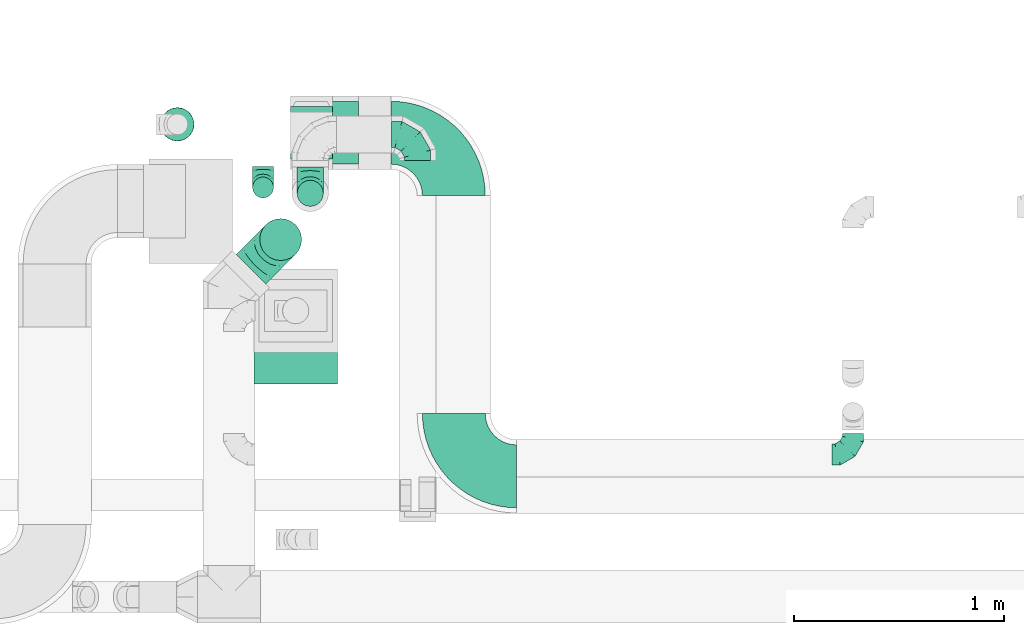
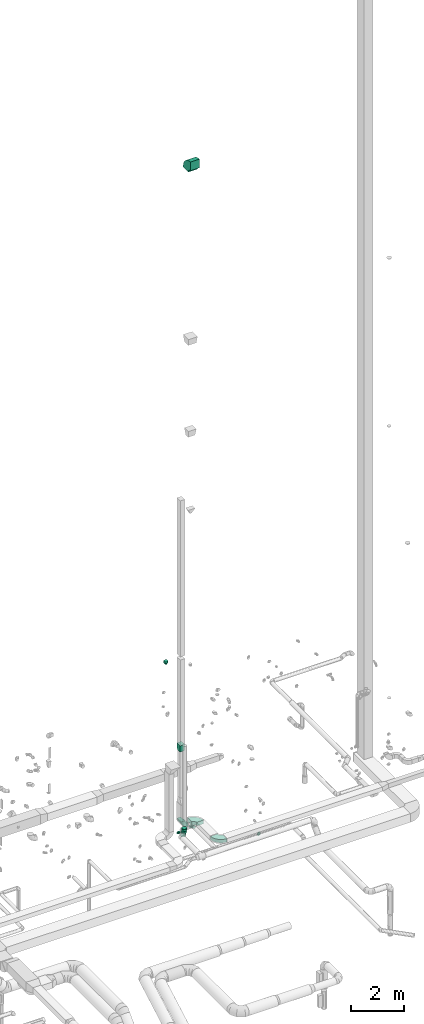
# One storey, part 66 of 97: 11 flow fittings, 1 flow segment.
"""IFC2X3 building model written with IfcOpenShell, lengths in millimetres."""

from ifc_helpers import new_model, entity, si_unit, converted_unit, derived_unit, direction, frame, frame_2d, origin, origin_2d_with_axis, place, context, subcontext, project, spatial, polyline, circle_curve, parameter, trimmed, segment, composite_curve, circle, outline, extrude, faceted_brep, source, transform, mapped, material, type_object, type_shapes, element, save


model = new_model("IFC2X3")

# Units and contexts
model_context = context("Model", 3, precision=0.01, world=origin(), true_north=direction((6.12303176911189e-17, 1.0)))
body_context = subcontext(model_context, "Body", "Model", "MODEL_VIEW")
ifc_project = project(units=[si_unit("LENGTHUNIT", "METRE", prefix="MILLI"), si_unit("AREAUNIT", "SQUARE_METRE"), si_unit("VOLUMEUNIT", "CUBIC_METRE"), converted_unit("PLANEANGLEUNIT", "DEGREE", entity("IfcRatioMeasure", 0.0174532925199433), si_unit("PLANEANGLEUNIT", "RADIAN"), dimensions=[0, 0, 0, 0, 0, 0, 0]), si_unit("MASSUNIT", "GRAM", prefix="KILO"), derived_unit("MASSDENSITYUNIT", [(si_unit("MASSUNIT", "GRAM", prefix="KILO"), 1), (si_unit("LENGTHUNIT", "METRE"), -3)]), derived_unit("MOMENTOFINERTIAUNIT", [(si_unit("LENGTHUNIT", "METRE"), 4)]), si_unit("TIMEUNIT", "SECOND"), si_unit("FREQUENCYUNIT", "HERTZ"), si_unit("THERMODYNAMICTEMPERATUREUNIT", "DEGREE_CELSIUS"), derived_unit("THERMALTRANSMITTANCEUNIT", [(si_unit("MASSUNIT", "GRAM", prefix="KILO"), 1), (si_unit("THERMODYNAMICTEMPERATUREUNIT", "KELVIN"), -1), (si_unit("TIMEUNIT", "SECOND"), -3)]), derived_unit("VOLUMETRICFLOWRATEUNIT", [(si_unit("LENGTHUNIT", "METRE"), 3), (si_unit("TIMEUNIT", "SECOND"), -1)]), derived_unit("MASSFLOWRATEUNIT", [(si_unit("MASSUNIT", "GRAM", prefix="KILO"), 1), (si_unit("TIMEUNIT", "SECOND"), -1)]), derived_unit("ROTATIONALFREQUENCYUNIT", [(si_unit("TIMEUNIT", "SECOND"), -1)]), si_unit("ELECTRICCURRENTUNIT", "AMPERE"), si_unit("ELECTRICVOLTAGEUNIT", "VOLT"), si_unit("POWERUNIT", "WATT"), si_unit("FORCEUNIT", "NEWTON", prefix="KILO"), si_unit("ILLUMINANCEUNIT", "LUX"), si_unit("LUMINOUSFLUXUNIT", "LUMEN"), si_unit("LUMINOUSINTENSITYUNIT", "CANDELA"), derived_unit("USERDEFINED", [(si_unit("MASSUNIT", "GRAM", prefix="KILO"), -1), (si_unit("LENGTHUNIT", "METRE"), -2), (si_unit("TIMEUNIT", "SECOND"), 3), (si_unit("LUMINOUSFLUXUNIT", "LUMEN"), 1)]), derived_unit("LINEARVELOCITYUNIT", [(si_unit("LENGTHUNIT", "METRE"), 1), (si_unit("TIMEUNIT", "SECOND"), -1)]), si_unit("PRESSUREUNIT", "PASCAL"), derived_unit("USERDEFINED", [(si_unit("LENGTHUNIT", "METRE"), -2), (si_unit("MASSUNIT", "GRAM", prefix="KILO"), 1), (si_unit("TIMEUNIT", "SECOND"), -2)]), derived_unit("LINEARFORCEUNIT", [(si_unit("MASSUNIT", "GRAM", prefix="KILO"), 1), (si_unit("LENGTHUNIT", "METRE"), 1), (si_unit("TIMEUNIT", "SECOND"), -2), (si_unit("LENGTHUNIT", "METRE"), -1)]), derived_unit("PLANARFORCEUNIT", [(si_unit("MASSUNIT", "GRAM", prefix="KILO"), 1), (si_unit("LENGTHUNIT", "METRE"), 1), (si_unit("TIMEUNIT", "SECOND"), -2), (si_unit("LENGTHUNIT", "METRE"), -2)])], contexts=[model_context])

# Site, building, storey
site_placement = place(None, origin())
site = spatial("IfcSite", under=ifc_project, at=site_placement, CompositionType="ELEMENT")
building_placement = place(site_placement, origin())
building = spatial("IfcBuilding", under=site, at=building_placement, CompositionType="ELEMENT")
storey_placement = place(building_placement, frame((0.0, 0.0, -4900.0)))
storey = spatial("IfcBuildingStorey", under=building, at=storey_placement, CompositionType="ELEMENT", Elevation=-4900.0)

# Flow segment
duct_segment_type = type_object("IfcDuctSegmentType", PredefinedType="NOTDEFINED")
flow_segment_placement = place(storey_placement, frame((58834.04, 11772.63, 12060.0)))
element("IfcFlowSegment", 1, at=flow_segment_placement, inside=storey, type_object=duct_segment_type, context=body_context, shape_type="SweptSolid", body=[
    extrude(circle(Radius=80.0, at=origin_2d_with_axis()), frame((81.6, 81.6, 0.0), z_axis=(0.0, 0.0, 1.0), x_axis=(0.0, 1.0, 0.0)), (0.0, 0.0, 1.0), 77.4999999999835),
])

# Flow fittings
ifc_material = material()
duct_fitting_type_1 = type_object("IfcDuctFittingType", PredefinedType="NOTDEFINED", material=ifc_material)
shared_shape_1 = source(origin(), body_context, "Body", "SweptSolid", [
    extrude(outline(polyline([(-159.86, -112.11), (141.18, -112.11), (157.79, 87.2), (-139.1, 137.03), (-159.86, -112.11)])), frame((150.0, -100.0, 0.0), z_axis=(0.0, 1.0, 0.0), x_axis=(0.996545758244872, 0.0, -0.0830454798538357)), (0.0, 0.0, 1.0), 200.0),
])
type_shapes(duct_fitting_type_1, [shared_shape_1])
flow_fitting_1_placement = place(storey_placement, frame((59555.69, 11814.2, 8095.4), z_axis=(0.0, -1.0, 0.0), x_axis=(0.0, 0.0, -1.0)))
element("IfcFlowFitting", 2, at=flow_fitting_1_placement, inside=storey, type_object=duct_fitting_type_1, material=ifc_material, context=body_context, shape_type="MappedRepresentation", body=[
    mapped(shared_shape_1, transform((0.0, 0.0, 0.0), scale=1.0)),
])
duct_fitting_type_2 = type_object("IfcDuctFittingType", PredefinedType="NOTDEFINED", material=ifc_material)
shared_shape_2 = source(origin(), body_context, "Body", "Brep", [
    faceted_brep([(-100.0, 0.0, -50.0), (-100.0, -12.94, -48.3), (-100.0, -25.0, -43.3), (-100.0, -35.36, -35.36), (-100.0, -43.3, -25.0), (-100.0, -48.3, -12.94), (-100.0, -50.0, 0.0), (-100.0, -48.3, 12.94), (-100.0, -43.3, 25.0), (-100.0, -35.36, 35.36), (-100.0, -25.0, 43.3), (-100.0, -12.94, 48.3), (-100.0, 0.0, 50.0), (-100.0, 12.94, 48.3), (-100.0, 25.0, 43.3), (-100.0, 35.36, 35.36), (-100.0, 43.3, 25.0), (-100.0, 48.3, 12.94), (-100.0, 50.0, 0.0), (-100.0, 48.3, -12.94), (-100.0, 43.3, -25.0), (-100.0, 35.36, -35.36), (-100.0, 25.0, -43.3), (-100.0, 12.94, -48.3), (-76.67, 12.94, 48.3), (-79.9, 25.0, 43.3), (-73.21, 0.0, 50.0), (-82.68, 35.36, 35.36), (-86.15, 48.3, 12.94), (-86.6, 50.0, 0.0), (-84.81, 43.3, 25.0), (-84.81, 43.3, -25.0), (-82.68, 35.36, -35.36), (-86.15, 48.3, -12.94), (-76.67, 12.94, -48.3), (-73.21, 0.0, -50.0), (-79.9, 25.0, -43.3), (-69.74, -12.94, -48.3), (-66.51, -25.0, -43.3), (-63.73, -35.36, -35.36), (-61.6, -43.3, -25.0), (-60.26, -48.3, -12.94), (-59.81, -50.0, 0.0), (-60.26, -48.3, 12.94), (-61.6, -43.3, 25.0), (-63.73, -35.36, 35.36), (-66.51, -25.0, 43.3), (-69.74, -12.94, 48.3), (-36.27, 36.27, 48.3), (-45.1, 45.1, 43.3), (-26.79, 26.79, 50.0), (-52.68, 52.68, 35.36), (-58.49, 58.49, 25.0), (-62.15, 62.15, 12.94), (-63.4, 63.4, 0.0), (-62.15, 62.15, -12.94), (-58.49, 58.49, -25.0), (-52.68, 52.68, -35.36), (-36.27, 36.27, -48.3), (-26.79, 26.79, -50.0), (-45.1, 45.1, -43.3), (-17.32, 17.32, -48.3), (-8.49, 8.49, -43.3), (-0.91, 0.91, -35.36), (4.9, -4.9, -25.0), (8.56, -8.56, -12.94), (9.81, -9.81, 0.0), (8.56, -8.56, 12.94), (4.9, -4.9, 25.0), (-0.91, 0.91, 35.36), (-8.49, 8.49, 43.3), (-17.32, 17.32, 48.3), (-12.94, 76.67, 48.3), (-25.0, 79.9, 43.3), (0.0, 73.21, 50.0), (-35.36, 82.68, 35.36), (-43.3, 84.81, 25.0), (-48.3, 86.15, 12.94), (-50.0, 86.6, 0.0), (-48.3, 86.15, -12.94), (-43.3, 84.81, -25.0), (-35.36, 82.68, -35.36), (-12.94, 76.67, -48.3), (0.0, 73.21, -50.0), (-25.0, 79.9, -43.3), (12.94, 69.74, -48.3), (25.0, 66.51, -43.3), (35.36, 63.73, -35.36), (43.3, 61.6, -25.0), (48.3, 60.26, -12.94), (50.0, 59.81, 0.0), (48.3, 60.26, 12.94), (43.3, 61.6, 25.0), (35.36, 63.73, 35.36), (25.0, 66.51, 43.3), (12.94, 69.74, 48.3), (-12.94, 100.0, -48.3), (-25.0, 100.0, -43.3), (-35.36, 100.0, -35.36), (-43.3, 100.0, -25.0), (-48.3, 100.0, -12.94), (-50.0, 100.0, 0.0), (-48.3, 100.0, 12.94), (-43.3, 100.0, 25.0), (-35.36, 100.0, 35.36), (-25.0, 100.0, 43.3), (-12.94, 100.0, 48.3), (0.0, 100.0, 50.0), (12.94, 100.0, 48.3), (25.0, 100.0, 43.3), (35.36, 100.0, 35.36), (43.3, 100.0, 25.0), (48.3, 100.0, 12.94), (50.0, 100.0, 0.0), (48.3, 100.0, -12.94), (43.3, 100.0, -25.0), (35.36, 100.0, -35.36), (25.0, 100.0, -43.3), (12.94, 100.0, -48.3), (0.0, 100.0, -50.0)], [[[0, 1, 2, 3, 4, 5, 6, 7, 8, 9, 10, 11, 12, 13, 14, 15, 16, 17, 18, 19, 20, 21, 22, 23]], [[24, 25, 14, 13]], [[26, 24, 13, 12]], [[14, 25, 27, 15]], [[28, 29, 18, 17]], [[30, 28, 17, 16]], [[15, 27, 30, 16]], [[20, 31, 32, 21]], [[33, 31, 20, 19]], [[18, 29, 33, 19]], [[34, 35, 0, 23]], [[36, 34, 23, 22]], [[32, 36, 22, 21]], [[2, 1, 37, 38]], [[3, 2, 38, 39]], [[0, 35, 37, 1]], [[5, 4, 40, 41]], [[6, 5, 41, 42]], [[3, 39, 40, 4]], [[6, 42, 43, 7]], [[7, 43, 44, 8]], [[8, 44, 45, 9]], [[10, 46, 47, 11]], [[11, 47, 26, 12]], [[10, 9, 45, 46]], [[48, 49, 25, 24]], [[50, 48, 24, 26]], [[27, 25, 49, 51]], [[52, 53, 28, 30]], [[51, 52, 30, 27]], [[29, 28, 53, 54]], [[55, 56, 31, 33]], [[54, 55, 33, 29]], [[57, 32, 31, 56]], [[58, 59, 35, 34]], [[60, 58, 34, 36]], [[57, 60, 36, 32]], [[37, 35, 59, 61]], [[38, 37, 61, 62]], [[39, 38, 62, 63]], [[41, 40, 64, 65]], [[42, 41, 65, 66]], [[63, 64, 40, 39]], [[43, 42, 66, 67]], [[44, 43, 67, 68]], [[68, 69, 45, 44]], [[46, 45, 69, 70]], [[47, 46, 70, 71]], [[26, 47, 71, 50]], [[72, 73, 49, 48]], [[74, 72, 48, 50]], [[51, 49, 73, 75]], [[76, 77, 53, 52]], [[75, 76, 52, 51]], [[54, 53, 77, 78]], [[79, 80, 56, 55]], [[78, 79, 55, 54]], [[81, 57, 56, 80]], [[82, 83, 59, 58]], [[84, 82, 58, 60]], [[81, 84, 60, 57]], [[61, 59, 83, 85]], [[62, 61, 85, 86]], [[63, 62, 86, 87]], [[65, 64, 88, 89]], [[66, 65, 89, 90]], [[87, 88, 64, 63]], [[67, 66, 90, 91]], [[68, 67, 91, 92]], [[92, 93, 69, 68]], [[70, 69, 93, 94]], [[71, 70, 94, 95]], [[50, 71, 95, 74]], [[96, 97, 98, 99, 100, 101, 102, 103, 104, 105, 106, 107, 108, 109, 110, 111, 112, 113, 114, 115, 116, 117, 118, 119]], [[72, 74, 107, 106]], [[73, 72, 106, 105]], [[75, 73, 105, 104]], [[77, 76, 103, 102]], [[78, 77, 102, 101]], [[75, 104, 103, 76]], [[78, 101, 100, 79]], [[79, 100, 99, 80]], [[80, 99, 98, 81]], [[96, 119, 83, 82]], [[97, 96, 82, 84]], [[84, 81, 98, 97]], [[83, 119, 118, 85]], [[85, 118, 117, 86]], [[86, 117, 116, 87]], [[88, 115, 114, 89]], [[89, 114, 113, 90]], [[87, 116, 115, 88]], [[91, 90, 113, 112]], [[92, 91, 112, 111]], [[93, 92, 111, 110]], [[95, 94, 109, 108]], [[74, 95, 108, 107]], [[110, 109, 94, 93]]]),
])
type_shapes(duct_fitting_type_2, [shared_shape_2])
flow_fitting_2_placement = place(storey_placement, frame((62140.26, 10278.7, 3925.0)))
element("IfcFlowFitting", 3, at=flow_fitting_2_placement, inside=storey, type_object=duct_fitting_type_2, material=ifc_material, context=body_context, shape_type="MappedRepresentation", body=[
    mapped(shared_shape_2, transform((0.0, 0.0, 0.0), scale=1.0)),
])
flow_fitting_3_placement = place(storey_placement, frame((59324.53, 11553.05, 4150.0), z_axis=(-1.0, 0.0, 0.0), x_axis=(0.0, -1.0, 0.0)))
element("IfcFlowFitting", 4, at=flow_fitting_3_placement, inside=storey, type_object=duct_fitting_type_2, material=ifc_material, context=body_context, shape_type="MappedRepresentation", body=[
    mapped(shared_shape_2, transform((0.0, 0.0, 0.0), scale=1.0)),
])
duct_fitting_type_3 = type_object("IfcDuctFittingType", PredefinedType="NOTDEFINED", material=ifc_material)
shared_shape_3 = source(origin(), body_context, "Body", "Brep", [
    faceted_brep([(-200.0, 0.0, -100.0), (-200.0, -25.88, -96.59), (-200.0, -50.0, -86.6), (-200.0, -70.71, -70.71), (-200.0, -86.6, -50.0), (-200.0, -96.59, -25.88), (-200.0, -100.0, 0.0), (-200.0, -96.59, 25.88), (-200.0, -86.6, 50.0), (-200.0, -70.71, 70.71), (-200.0, -50.0, 86.6), (-200.0, -25.88, 96.59), (-200.0, 0.0, 100.0), (-200.0, 25.88, 96.59), (-200.0, 50.0, 86.6), (-200.0, 70.71, 70.71), (-200.0, 86.6, 50.0), (-200.0, 96.59, 25.88), (-200.0, 100.0, 0.0), (-200.0, 96.59, -25.88), (-200.0, 86.6, -50.0), (-200.0, 70.71, -70.71), (-200.0, 50.0, -86.6), (-200.0, 25.88, -96.59), (-153.35, 25.88, 96.59), (-159.81, 50.0, 86.6), (-146.41, 0.0, 100.0), (-165.36, 70.71, 70.71), (-172.29, 96.59, 25.88), (-173.21, 100.0, 0.0), (-169.62, 86.6, 50.0), (-169.62, 86.6, -50.0), (-165.36, 70.71, -70.71), (-172.29, 96.59, -25.88), (-153.35, 25.88, -96.59), (-146.41, 0.0, -100.0), (-159.81, 50.0, -86.6), (-139.48, -25.88, -96.59), (-133.01, -50.0, -86.6), (-127.46, -70.71, -70.71), (-123.21, -86.6, -50.0), (-120.53, -96.59, -25.88), (-119.62, -100.0, 0.0), (-120.53, -96.59, 25.88), (-123.21, -86.6, 50.0), (-127.46, -70.71, 70.71), (-133.01, -50.0, 86.6), (-139.48, -25.88, 96.59), (-72.54, 72.54, 96.59), (-90.19, 90.19, 86.6), (-53.59, 53.59, 100.0), (-105.35, 105.35, 70.71), (-116.99, 116.99, 50.0), (-124.3, 124.3, 25.88), (-126.79, 126.79, 0.0), (-124.3, 124.3, -25.88), (-116.99, 116.99, -50.0), (-105.35, 105.35, -70.71), (-72.54, 72.54, -96.59), (-53.59, 53.59, -100.0), (-90.19, 90.19, -86.6), (-34.64, 34.64, -96.59), (-16.99, 16.99, -86.6), (-1.83, 1.83, -70.71), (9.81, -9.81, -50.0), (17.12, -17.12, -25.88), (19.62, -19.62, 0.0), (17.12, -17.12, 25.88), (9.81, -9.81, 50.0), (-1.83, 1.83, 70.71), (-16.99, 16.99, 86.6), (-34.64, 34.64, 96.59), (-25.88, 153.35, 96.59), (-50.0, 159.81, 86.6), (0.0, 146.41, 100.0), (-70.71, 165.36, 70.71), (-86.6, 169.62, 50.0), (-96.59, 172.29, 25.88), (-100.0, 173.21, 0.0), (-96.59, 172.29, -25.88), (-86.6, 169.62, -50.0), (-70.71, 165.36, -70.71), (-25.88, 153.35, -96.59), (0.0, 146.41, -100.0), (-50.0, 159.81, -86.6), (25.88, 139.48, -96.59), (50.0, 133.01, -86.6), (70.71, 127.46, -70.71), (86.6, 123.21, -50.0), (96.59, 120.53, -25.88), (100.0, 119.62, 0.0), (96.59, 120.53, 25.88), (86.6, 123.21, 50.0), (70.71, 127.46, 70.71), (50.0, 133.01, 86.6), (25.88, 139.48, 96.59), (-25.88, 200.0, -96.59), (-50.0, 200.0, -86.6), (-70.71, 200.0, -70.71), (-86.6, 200.0, -50.0), (-96.59, 200.0, -25.88), (-100.0, 200.0, 0.0), (-96.59, 200.0, 25.88), (-86.6, 200.0, 50.0), (-70.71, 200.0, 70.71), (-50.0, 200.0, 86.6), (-25.88, 200.0, 96.59), (0.0, 200.0, 100.0), (25.88, 200.0, 96.59), (50.0, 200.0, 86.6), (70.71, 200.0, 70.71), (86.6, 200.0, 50.0), (96.59, 200.0, 25.88), (100.0, 200.0, 0.0), (96.59, 200.0, -25.88), (86.6, 200.0, -50.0), (70.71, 200.0, -70.71), (50.0, 200.0, -86.6), (25.88, 200.0, -96.59), (0.0, 200.0, -100.0)], [[[0, 1, 2, 3, 4, 5, 6, 7, 8, 9, 10, 11, 12, 13, 14, 15, 16, 17, 18, 19, 20, 21, 22, 23]], [[24, 25, 14, 13]], [[26, 24, 13, 12]], [[14, 25, 27, 15]], [[28, 29, 18, 17]], [[30, 28, 17, 16]], [[15, 27, 30, 16]], [[20, 31, 32, 21]], [[33, 31, 20, 19]], [[18, 29, 33, 19]], [[34, 35, 0, 23]], [[36, 34, 23, 22]], [[32, 36, 22, 21]], [[1, 0, 35, 37]], [[2, 1, 37, 38]], [[38, 39, 3, 2]], [[5, 4, 40, 41]], [[6, 5, 41, 42]], [[39, 40, 4, 3]], [[6, 42, 43, 7]], [[7, 43, 44, 8]], [[8, 44, 45, 9]], [[9, 45, 46, 10]], [[10, 46, 47, 11]], [[26, 12, 11, 47]], [[48, 49, 25, 24]], [[50, 48, 24, 26]], [[27, 25, 49, 51]], [[52, 53, 28, 30]], [[51, 52, 30, 27]], [[29, 28, 53, 54]], [[55, 56, 31, 33]], [[54, 55, 33, 29]], [[32, 31, 56, 57]], [[58, 59, 35, 34]], [[60, 58, 34, 36]], [[57, 60, 36, 32]], [[37, 35, 59, 61]], [[38, 37, 61, 62]], [[39, 38, 62, 63]], [[41, 40, 64, 65]], [[42, 41, 65, 66]], [[63, 64, 40, 39]], [[43, 42, 66, 67]], [[44, 43, 67, 68]], [[68, 69, 45, 44]], [[46, 45, 69, 70]], [[47, 46, 70, 71]], [[26, 47, 71, 50]], [[72, 73, 49, 48]], [[74, 72, 48, 50]], [[51, 49, 73, 75]], [[76, 77, 53, 52]], [[75, 76, 52, 51]], [[54, 53, 77, 78]], [[79, 80, 56, 55]], [[78, 79, 55, 54]], [[57, 56, 80, 81]], [[82, 83, 59, 58]], [[84, 82, 58, 60]], [[81, 84, 60, 57]], [[61, 59, 83, 85]], [[62, 61, 85, 86]], [[63, 62, 86, 87]], [[65, 64, 88, 89]], [[66, 65, 89, 90]], [[87, 88, 64, 63]], [[67, 66, 90, 91]], [[68, 67, 91, 92]], [[92, 93, 69, 68]], [[70, 69, 93, 94]], [[71, 70, 94, 95]], [[50, 71, 95, 74]], [[96, 97, 98, 99, 100, 101, 102, 103, 104, 105, 106, 107, 108, 109, 110, 111, 112, 113, 114, 115, 116, 117, 118, 119]], [[72, 74, 107, 106]], [[73, 72, 106, 105]], [[75, 73, 105, 104]], [[102, 101, 78, 77]], [[103, 102, 77, 76]], [[75, 104, 103, 76]], [[78, 101, 100, 79]], [[79, 100, 99, 80]], [[80, 99, 98, 81]], [[84, 97, 96, 82]], [[82, 96, 119, 83]], [[84, 81, 98, 97]], [[118, 117, 86, 85]], [[119, 118, 85, 83]], [[116, 87, 86, 117]], [[88, 115, 114, 89]], [[89, 114, 113, 90]], [[115, 88, 87, 116]], [[91, 90, 113, 112]], [[92, 91, 112, 111]], [[111, 110, 93, 92]], [[95, 94, 109, 108]], [[74, 95, 108, 107]], [[110, 109, 94, 93]]]),
])
type_shapes(duct_fitting_type_3, [shared_shape_3])
flow_fitting_4_placement = place(storey_placement, frame((59408.94, 11304.18, 4350.0), z_axis=(0.707106781186499, -0.707106781186597, 0.0), x_axis=(0.707106781186597, 0.707106781186499, 0.0)))
element("IfcFlowFitting", 5, at=flow_fitting_4_placement, inside=storey, type_object=duct_fitting_type_3, material=ifc_material, context=body_context, shape_type="MappedRepresentation", body=[
    mapped(shared_shape_3, transform((0.0, 0.0, 0.0), scale=1.0)),
])
duct_fitting_type_4 = type_object("IfcDuctFittingType", PredefinedType="NOTDEFINED", material=ifc_material)
shared_shape_4 = source(origin(), body_context, "Body", "Brep", [
    faceted_brep([(-125.0, 0.0, -62.5), (-125.0, -16.18, -60.37), (-125.0, -31.25, -54.13), (-125.0, -44.19, -44.19), (-125.0, -54.13, -31.25), (-125.0, -60.37, -16.18), (-125.0, -62.5, 0.0), (-125.0, -60.37, 16.18), (-125.0, -54.13, 31.25), (-125.0, -44.19, 44.19), (-125.0, -31.25, 54.13), (-125.0, -16.18, 60.37), (-125.0, 0.0, 62.5), (-125.0, 16.18, 60.37), (-125.0, 31.25, 54.13), (-125.0, 44.19, 44.19), (-125.0, 54.13, 31.25), (-125.0, 60.37, 16.18), (-125.0, 62.5, 0.0), (-125.0, 60.37, -16.18), (-125.0, 54.13, -31.25), (-125.0, 44.19, -44.19), (-125.0, 31.25, -54.13), (-125.0, 16.18, -60.37), (-95.84, 16.18, 60.37), (-99.88, 31.25, 54.13), (-91.51, 0.0, 62.5), (-103.35, 44.19, 44.19), (-107.68, 60.37, 16.18), (-108.25, 62.5, 0.0), (-106.01, 54.13, 31.25), (-106.01, 54.13, -31.25), (-103.35, 44.19, -44.19), (-107.68, 60.37, -16.18), (-95.84, 16.18, -60.37), (-91.51, 0.0, -62.5), (-99.88, 31.25, -54.13), (-87.17, -16.18, -60.37), (-83.13, -31.25, -54.13), (-79.66, -44.19, -44.19), (-77.0, -54.13, -31.25), (-75.33, -60.37, -16.18), (-74.76, -62.5, 0.0), (-75.33, -60.37, 16.18), (-77.0, -54.13, 31.25), (-79.66, -44.19, 44.19), (-83.13, -31.25, 54.13), (-87.17, -16.18, 60.37), (-45.34, 45.34, 60.37), (-56.37, 56.37, 54.13), (-33.49, 33.49, 62.5), (-65.85, 65.85, 44.19), (-73.12, 73.12, 31.25), (-77.69, 77.69, 16.18), (-79.25, 79.25, 0.0), (-77.69, 77.69, -16.18), (-73.12, 73.12, -31.25), (-65.85, 65.85, -44.19), (-45.34, 45.34, -60.37), (-33.49, 33.49, -62.5), (-56.37, 56.37, -54.13), (-21.65, 21.65, -60.37), (-10.62, 10.62, -54.13), (-1.14, 1.14, -44.19), (6.13, -6.13, -31.25), (10.7, -10.7, -16.18), (12.26, -12.26, 0.0), (10.7, -10.7, 16.18), (6.13, -6.13, 31.25), (-1.14, 1.14, 44.19), (-10.62, 10.62, 54.13), (-21.65, 21.65, 60.37), (-16.18, 95.84, 60.37), (-31.25, 99.88, 54.13), (0.0, 91.51, 62.5), (-44.19, 103.35, 44.19), (-54.13, 106.01, 31.25), (-60.37, 107.68, 16.18), (-62.5, 108.25, 0.0), (-60.37, 107.68, -16.18), (-54.13, 106.01, -31.25), (-44.19, 103.35, -44.19), (-16.18, 95.84, -60.37), (0.0, 91.51, -62.5), (-31.25, 99.88, -54.13), (16.18, 87.17, -60.37), (31.25, 83.13, -54.13), (44.19, 79.66, -44.19), (54.13, 77.0, -31.25), (60.37, 75.33, -16.18), (62.5, 74.76, 0.0), (60.37, 75.33, 16.18), (54.13, 77.0, 31.25), (44.19, 79.66, 44.19), (31.25, 83.13, 54.13), (16.18, 87.17, 60.37), (-16.18, 125.0, -60.37), (-31.25, 125.0, -54.13), (-44.19, 125.0, -44.19), (-54.13, 125.0, -31.25), (-60.37, 125.0, -16.18), (-62.5, 125.0, 0.0), (-60.37, 125.0, 16.18), (-54.13, 125.0, 31.25), (-44.19, 125.0, 44.19), (-31.25, 125.0, 54.13), (-16.18, 125.0, 60.37), (0.0, 125.0, 62.5), (16.18, 125.0, 60.37), (31.25, 125.0, 54.13), (44.19, 125.0, 44.19), (54.13, 125.0, 31.25), (60.37, 125.0, 16.18), (62.5, 125.0, 0.0), (60.37, 125.0, -16.18), (54.13, 125.0, -31.25), (44.19, 125.0, -44.19), (31.25, 125.0, -54.13), (16.18, 125.0, -60.37), (0.0, 125.0, -62.5)], [[[0, 1, 2, 3, 4, 5, 6, 7, 8, 9, 10, 11, 12, 13, 14, 15, 16, 17, 18, 19, 20, 21, 22, 23]], [[24, 25, 14, 13]], [[26, 24, 13, 12]], [[14, 25, 27, 15]], [[28, 29, 18, 17]], [[30, 28, 17, 16]], [[15, 27, 30, 16]], [[20, 31, 32, 21]], [[33, 31, 20, 19]], [[18, 29, 33, 19]], [[34, 35, 0, 23]], [[36, 34, 23, 22]], [[21, 32, 36, 22]], [[1, 0, 35, 37]], [[2, 1, 37, 38]], [[38, 39, 3, 2]], [[5, 4, 40, 41]], [[6, 5, 41, 42]], [[39, 40, 4, 3]], [[6, 42, 43, 7]], [[7, 43, 44, 8]], [[45, 9, 8, 44]], [[9, 45, 46, 10]], [[10, 46, 47, 11]], [[26, 12, 11, 47]], [[48, 49, 25, 24]], [[50, 48, 24, 26]], [[27, 25, 49, 51]], [[52, 53, 28, 30]], [[51, 52, 30, 27]], [[29, 28, 53, 54]], [[55, 56, 31, 33]], [[54, 55, 33, 29]], [[57, 32, 31, 56]], [[58, 59, 35, 34]], [[60, 58, 34, 36]], [[57, 60, 36, 32]], [[37, 35, 59, 61]], [[38, 37, 61, 62]], [[39, 38, 62, 63]], [[41, 40, 64, 65]], [[42, 41, 65, 66]], [[63, 64, 40, 39]], [[43, 42, 66, 67]], [[44, 43, 67, 68]], [[68, 69, 45, 44]], [[46, 45, 69, 70]], [[47, 46, 70, 71]], [[26, 47, 71, 50]], [[72, 73, 49, 48]], [[74, 72, 48, 50]], [[51, 49, 73, 75]], [[76, 77, 53, 52]], [[75, 76, 52, 51]], [[54, 53, 77, 78]], [[79, 80, 56, 55]], [[78, 79, 55, 54]], [[81, 57, 56, 80]], [[82, 83, 59, 58]], [[84, 82, 58, 60]], [[81, 84, 60, 57]], [[61, 59, 83, 85]], [[62, 61, 85, 86]], [[63, 62, 86, 87]], [[65, 64, 88, 89]], [[66, 65, 89, 90]], [[87, 88, 64, 63]], [[67, 66, 90, 91]], [[68, 67, 91, 92]], [[92, 93, 69, 68]], [[70, 69, 93, 94]], [[71, 70, 94, 95]], [[50, 71, 95, 74]], [[96, 97, 98, 99, 100, 101, 102, 103, 104, 105, 106, 107, 108, 109, 110, 111, 112, 113, 114, 115, 116, 117, 118, 119]], [[72, 74, 107, 106]], [[73, 72, 106, 105]], [[75, 73, 105, 104]], [[77, 76, 103, 102]], [[78, 77, 102, 101]], [[75, 104, 103, 76]], [[78, 101, 100, 79]], [[79, 100, 99, 80]], [[80, 99, 98, 81]], [[96, 119, 83, 82]], [[97, 96, 82, 84]], [[84, 81, 98, 97]], [[83, 119, 118, 85]], [[85, 118, 117, 86]], [[116, 87, 86, 117]], [[88, 115, 114, 89]], [[89, 114, 113, 90]], [[115, 88, 87, 116]], [[91, 90, 113, 112]], [[92, 91, 112, 111]], [[111, 110, 93, 92]], [[95, 94, 109, 108]], [[74, 95, 108, 107]], [[110, 109, 94, 93]]]),
])
type_shapes(duct_fitting_type_4, [shared_shape_4])
for number, where, z_axis, x_axis in (
    (6, (59549.99, 11524.89, 4115.0), (-1.0, -1.18060942355669e-08, 0.0), (1.18060942355669e-08, -1.0, 0.0)),
    (7, (60062.65, 11805.87, 4115.0), (0.0, 0.0, 1.0), (0.0, 1.0, 0.0)),
):
    element("IfcFlowFitting", number, at=place(storey_placement, frame(where, z_axis=z_axis, x_axis=x_axis)), inside=storey, type_object=duct_fitting_type_4, material=ifc_material, context=body_context, shape_type="MappedRepresentation", body=[
        mapped(shared_shape_4, transform((0.0, 0.0, 0.0), scale=1.0)),
    ])
duct_fitting_type_5 = type_object("IfcDuctFittingType", PredefinedType="NOTDEFINED", material=ifc_material)
shared_shape_5 = source(origin(), body_context, "Body", "Brep", [
    faceted_brep([(60.0, 0.0, -80.0), (60.0, 14.27, -77.16), (60.0, 30.61, -73.91), (60.0, 43.59, -65.24), (60.0, 56.57, -56.57), (60.0, 65.24, -43.59), (60.0, 73.91, -30.61), (60.0, 77.16, -14.27), (60.0, 80.0, 0.0), (60.0, 77.16, 14.27), (60.0, 73.91, 30.61), (60.0, 65.24, 43.59), (60.0, 56.57, 56.57), (60.0, 43.59, 65.24), (60.0, 30.61, 73.91), (60.0, 14.27, 77.16), (60.0, 0.0, 80.0), (60.0, -14.27, 77.16), (60.0, -30.61, 73.91), (60.0, -43.59, 65.24), (60.0, -56.57, 56.57), (60.0, -65.24, 43.59), (60.0, -73.91, 30.61), (60.0, -77.16, 14.27), (60.0, -80.0, 0.0), (60.0, -77.16, -14.27), (60.0, -73.91, -30.61), (60.0, -65.24, -43.59), (60.0, -56.57, -56.57), (60.0, -43.59, -65.24), (60.0, -30.61, -73.91), (60.0, -14.27, -77.16), (0.0, -19.13, -46.19), (0.0, -27.24, -40.77), (0.0, -35.36, -35.36), (0.0, -40.77, -27.24), (0.0, -46.19, -19.13), (0.0, -48.1, -9.57), (0.0, -50.0, 0.0), (0.0, -48.1, 9.57), (0.0, -46.19, 19.13), (0.0, -40.77, 27.24), (0.0, -35.36, 35.36), (0.0, -27.24, 40.77), (0.0, -19.13, 46.19), (0.0, -9.57, 48.1), (0.0, 0.0, 50.0), (0.0, 9.57, 48.1), (0.0, 19.13, 46.19), (0.0, 27.24, 40.77), (0.0, 35.36, 35.36), (0.0, 40.77, 27.24), (0.0, 46.19, 19.13), (0.0, 48.1, 9.57), (0.0, 50.0, 0.0), (0.0, 48.1, -9.57), (0.0, 46.19, -19.13), (0.0, 40.77, -27.24), (0.0, 35.36, -35.36), (0.0, 27.24, -40.77), (0.0, 19.13, -46.19), (0.0, 9.57, -48.1), (0.0, 0.0, -50.0), (0.0, -9.57, -48.1)], [[[0, 1, 2, 3, 4, 5, 6, 7, 8, 9, 10, 11, 12, 13, 14, 15, 16, 17, 18, 19, 20, 21, 22, 23, 24, 25, 26, 27, 28, 29, 30, 31]], [[32, 33, 34, 35, 36, 37, 38, 39, 40, 41, 42, 43, 44, 45, 46, 47, 48, 49, 50, 51, 52, 53, 54, 55, 56, 57, 58, 59, 60, 61, 62, 63]], [[52, 51, 50, 12, 11, 10]], [[48, 14, 13, 12, 50, 49]], [[10, 9, 8, 54, 53, 52]], [[15, 14, 48, 47, 46, 16]], [[44, 43, 42, 20, 19, 18]], [[40, 22, 21, 20, 42, 41]], [[18, 17, 16, 46, 45, 44]], [[23, 22, 40, 39, 38, 24]], [[36, 35, 34, 28, 27, 26]], [[32, 30, 29, 28, 34, 33]], [[26, 25, 24, 38, 37, 36]], [[31, 30, 32, 63, 62, 0]], [[60, 59, 58, 4, 3, 2]], [[56, 6, 5, 4, 58, 57]], [[2, 1, 0, 62, 61, 60]], [[7, 6, 56, 55, 54, 8]]]),
])
type_shapes(duct_fitting_type_5, [shared_shape_5])
flow_fitting_5_placement = place(storey_placement, frame((58915.63, 11854.23, 12000.0), z_axis=(-1.0, 0.0, 0.0), x_axis=(0.0, 0.0, 1.0)))
element("IfcFlowFitting", 8, at=flow_fitting_5_placement, inside=storey, type_object=duct_fitting_type_5, material=ifc_material, context=body_context, shape_type="MappedRepresentation", body=[
    mapped(shared_shape_5, transform((0.0, 0.0, 0.0), scale=1.0)),
])
duct_fitting_type_6 = type_object("IfcDuctFittingType", PredefinedType="NOTDEFINED", material=ifc_material)
shared_shape_6 = source(origin(), body_context, "Body", "SweptSolid", [
    extrude(outline(composite_curve([segment(polyline([(-300.0, -150.0), (0.0, -150.0)]), True, "CONTINUOUS"), segment(trimmed(circle_curve(frame_2d((150.0, -150.0), x_axis=(0.0, 1.0)), 150.0), [parameter(0.0)], [parameter(90.0)], True, "PARAMETER"), False, "CONTINUOUS"), segment(polyline([(150.0, 0.0), (150.0, 300.0)]), True, "CONTINUOUS"), segment(trimmed(circle_curve(frame_2d((150.0, -150.0), x_axis=(0.0, 1.0)), 450.0), [parameter(0.0)], [parameter(90.0000000000001)], True, "PARAMETER"), True, "CONTINUOUS")], self_intersect=False)), frame((-150.0, 150.0, -75.0), z_axis=(0.0, 0.0, 1.0), x_axis=(-1.0, 0.0, 0.0)), (0.0, 0.0, 1.0), 150.0),
])
type_shapes(duct_fitting_type_6, [shared_shape_6])
for number, where, z_axis, x_axis in (
    (9, (60235.27, 11814.2, 4350.0), (0.0, 0.0, 1.0), (0.0, 1.0, 0.0)),
    (10, (60235.27, 10174.06, 4350.0), (0.0, 0.0, 1.0), (0.0, -1.0, 0.0)),
):
    element("IfcFlowFitting", number, at=place(storey_placement, frame(where, z_axis=z_axis, x_axis=x_axis)), inside=storey, type_object=duct_fitting_type_6, material=ifc_material, context=body_context, shape_type="MappedRepresentation", body=[
        mapped(shared_shape_6, transform((0.0, 0.0, 0.0), scale=1.0)),
    ])
duct_fitting_type_7 = type_object("IfcDuctFittingType", PredefinedType="NOTDEFINED", material=ifc_material)
shared_shape_7 = source(origin(), body_context, "Body", "SweptSolid", [
    extrude(outline(composite_curve([segment(polyline([(-187.5, -112.5), (-37.5, -112.5)]), True, "CONTINUOUS"), segment(trimmed(circle_curve(frame_2d((112.5, -112.5), x_axis=(0.0, 1.0)), 150.0), [parameter(0.0)], [parameter(90.0000000000001)], True, "PARAMETER"), False, "CONTINUOUS"), segment(polyline([(112.5, 37.5), (112.5, 187.5)]), True, "CONTINUOUS"), segment(trimmed(circle_curve(frame_2d((112.5, -112.5), x_axis=(0.0, 1.0)), 300.0), [parameter(0.0)], [parameter(90.0000000000001)], True, "PARAMETER"), True, "CONTINUOUS")], self_intersect=False)), frame((-112.5, 112.5, -150.0), z_axis=(0.0, 0.0, 1.0), x_axis=(-1.0, 0.0, 0.0)), (0.0, 0.0, 1.0), 300.0),
])
type_shapes(duct_fitting_type_7, [shared_shape_7])
flow_fitting_6_placement = place(storey_placement, frame((59555.69, 11814.2, 4350.0), z_axis=(0.0, 1.0, 0.0), x_axis=(-1.0, 0.0, 0.0)))
element("IfcFlowFitting", 11, at=flow_fitting_6_placement, inside=storey, type_object=duct_fitting_type_7, material=ifc_material, context=body_context, shape_type="MappedRepresentation", body=[
    mapped(shared_shape_7, transform((0.0, 0.0, 0.0), scale=1.0)),
])
duct_fitting_type_8 = type_object("IfcDuctFittingType", PredefinedType="NOTDEFINED", material=ifc_material)
shared_shape_8 = source(origin(), body_context, "Body", "SweptSolid", [
    extrude(outline(composite_curve([segment(polyline([(-375.0, -175.0), (25.0, -175.0)]), True, "CONTINUOUS"), segment(trimmed(circle_curve(frame_2d((175.0, -175.0), x_axis=(0.0, 1.0)), 150.0), [parameter(0.0)], [parameter(90.0)], True, "PARAMETER"), False, "CONTINUOUS"), segment(polyline([(175.0, -25.0), (175.0, 375.0)]), True, "CONTINUOUS"), segment(trimmed(circle_curve(frame_2d((175.0, -175.0), x_axis=(0.0, 1.0)), 550.0), [parameter(0.0)], [parameter(90.0)], True, "PARAMETER"), True, "CONTINUOUS")], self_intersect=False)), frame((-175.0, 175.0, -200.0), z_axis=(0.0, 0.0, 1.0), x_axis=(-1.0, 0.0, 0.0)), (0.0, 0.0, 1.0), 400.0),
])
type_shapes(duct_fitting_type_8, [shared_shape_8])
flow_fitting_7_placement = place(storey_placement, frame((59480.56, 10964.63, 35700.0), z_axis=(1.0, 0.0, 0.0), x_axis=(0.0, 0.0, 1.0)))
element("IfcFlowFitting", 12, at=flow_fitting_7_placement, inside=storey, type_object=duct_fitting_type_8, material=ifc_material, context=body_context, shape_type="MappedRepresentation", body=[
    mapped(shared_shape_8, transform((0.0, 0.0, 0.0), scale=1.0)),
])

save(model, "model.ifc")
